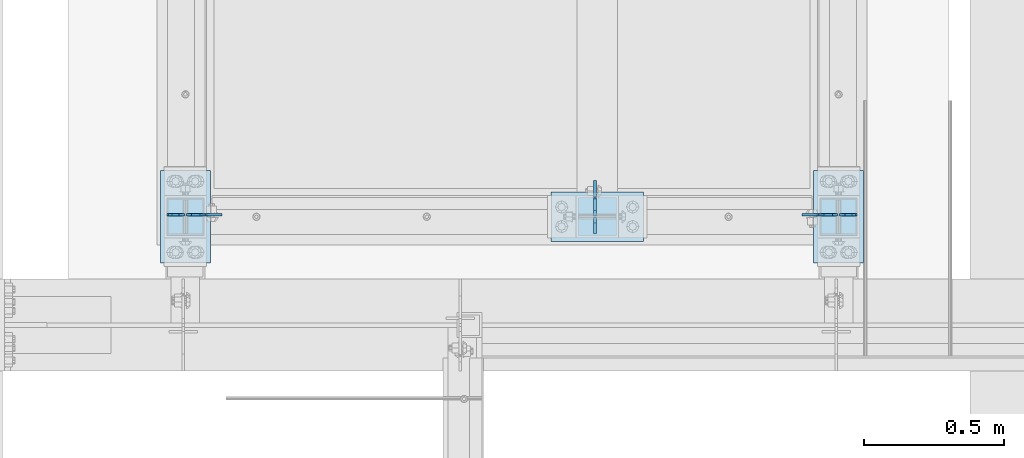
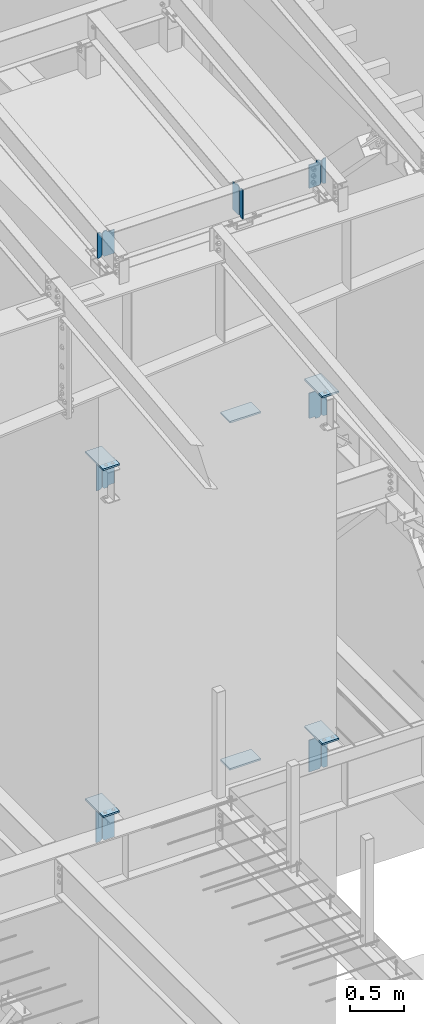
# One storey, part 1008 of 1179: 20 plates, 13 elements without a shape of their own.
"""IFC2X3 building model written with IfcOpenShell, lengths in millimetres."""

from ifc_helpers import new_model, si_unit, frame, origin_with_axes, place, context, subcontext, project, spatial, faceted_brep, material, type_object, element, aggregate, save


model = new_model("IFC2X3")

# Units and contexts
model_context = context("Model", 3, precision=1e-05, world=origin_with_axes())
body_context = subcontext(model_context, "Body", "Model", "MODEL_VIEW")
ifc_project = project(units=[si_unit("LENGTHUNIT", "METRE", prefix="MILLI"), si_unit("AREAUNIT", "SQUARE_METRE"), si_unit("VOLUMEUNIT", "CUBIC_METRE"), si_unit("MASSUNIT", "GRAM", prefix="KILO"), si_unit("TIMEUNIT", "SECOND"), si_unit("PLANEANGLEUNIT", "RADIAN"), si_unit("SOLIDANGLEUNIT", "STERADIAN"), si_unit("THERMODYNAMICTEMPERATUREUNIT", "DEGREE_CELSIUS"), si_unit("LUMINOUSINTENSITYUNIT", "LUMEN")], contexts=[model_context])

# Site, building, storey
site_placement = place(None, origin_with_axes())
site = spatial("IfcSite", under=ifc_project, at=site_placement, CompositionType="ELEMENT")
building_placement = place(site_placement, origin_with_axes())
building = spatial("IfcBuilding", under=site, at=building_placement, Name="Undefined", CompositionType="ELEMENT")
storey_placement = place(building_placement, origin_with_axes())
storey = spatial("IfcBuildingStorey", under=building, at=storey_placement, Name="Undefined", CompositionType="ELEMENT", Elevation=0.0)

# Assembly, plate
assembly_1_placement = place(storey_placement, origin_with_axes())
assembly_1 = element("IfcElementAssembly", 1, at=assembly_1_placement, inside=storey, Name="BEAM", AssemblyPlace="NOTDEFINED", PredefinedType="RIGID_FRAME")
ifc_material = material(Name="STEEL/A36")
plate_type_1 = type_object("IfcPlateType", PredefinedType="NOTDEFINED")
plate_1_placement = place(assembly_1_placement, frame((21479.175, 11876.0879998642, 10289.3409533501), z_axis=(0.0, 0.0, 1.0), x_axis=(1.0, 0.0, 0.0)))
plate_1 = element("IfcPlate", 2, at=plate_1_placement, type_object=plate_type_1, material=ifc_material, Name="PLATE", context=body_context, shape_type="Brep", body=[
    faceted_brep([(0.0, -4.76250000000073, 19.0499992370605), (0.0, -4.76250000000073, 266.862435780953), (0.0, 4.76250000000073, 266.862435780953), (0.0, 4.76250000000073, 19.0499992370605), (19.0499992370605, -4.76250000000073, 285.912435018014), (19.0499992370605, 4.76250000000073, 285.912435018014), (44.4500000000007, -4.76250000000073, 285.912435018014), (44.4500000000007, 4.76250000000073, 285.912435018014), (44.4500000000007, -4.76250000000073, 0.0), (44.4500000000007, 4.76250000000073, 0.0), (19.0499992370605, -4.76250000000073, 0.0), (19.0499992370605, 4.76250000000073, 0.0)], [[[0, 1, 2, 3]], [[1, 4, 5, 2]], [[4, 6, 7, 5]], [[6, 8, 9, 7]], [[8, 10, 11, 9]], [[10, 0, 3, 11]], [[5, 7, 9, 11, 3, 2]], [[10, 8, 6, 4, 1, 0]]]),
])

assembly_2_placement = place(storey_placement, origin_with_axes())
assembly_2 = element("IfcElementAssembly", 3, at=assembly_2_placement, inside=storey, Name="BEAM", AssemblyPlace="NOTDEFINED", PredefinedType="RIGID_FRAME")
plate_2_placement = place(assembly_2_placement, frame((19135.425, 11876.0879998642, 10289.3409533501), z_axis=(0.0, 0.0, 1.0), x_axis=(-1.0, 0.0, 0.0)))
plate_2 = element("IfcPlate", 4, at=plate_2_placement, type_object=plate_type_1, material=ifc_material, Name="PLATE", context=body_context, shape_type="Brep", body=[
    faceted_brep([(0.0, -4.76250000000073, 19.0499992370605), (0.0, -4.76250000000073, 266.862435780953), (0.0, 4.76250000000073, 266.862435780953), (0.0, 4.76250000000073, 19.0499992370605), (19.0499992370605, -4.76250000000073, 285.912435018014), (19.0499992370605, 4.76250000000073, 285.912435018014), (44.4500000000007, -4.76250000000073, 285.912435018014), (44.4500000000007, 4.76250000000073, 285.912435018014), (44.4500000000007, -4.76250000000073, 0.0), (44.4500000000007, 4.76250000000073, 0.0), (19.0499992370605, -4.76250000000073, 0.0), (19.0499992370605, 4.76250000000073, 0.0)], [[[0, 1, 2, 3]], [[1, 4, 5, 2]], [[4, 6, 7, 5]], [[6, 8, 9, 7]], [[8, 10, 11, 9]], [[10, 0, 3, 11]], [[5, 7, 9, 11, 3, 2]], [[10, 8, 6, 4, 1, 0]]]),
])

# Plate
plate_type_2 = type_object("IfcPlateType", PredefinedType="NOTDEFINED")
plate_3_placement = place(assembly_1_placement, frame((21472.225, 11876.0879998611, 10289.3409533498), z_axis=(0.0, 0.0, 1.0), x_axis=(-1.0, 0.0, 0.0)))
plate_3 = element("IfcPlate", 5, at=plate_3_placement, type_object=plate_type_2, material=ifc_material, Name="PLATE", context=body_context, shape_type="Brep", body=[
    faceted_brep([(47.3250000000007, -4.76250000000073, 285.912435018014), (47.3250000000007, -4.76250000000073, 278.748969282953), (47.3250000000007, 4.76250000000073, 278.748969282953), (47.3250000000007, 4.76250000000073, 285.912435018014), (48.2917299225883, -4.76250000000073, 273.888889764907), (48.2917299225883, 4.76250000000073, 273.888889764907), (51.0447438230658, -4.76250000000073, 269.768713296753), (51.0447438230658, 4.76250000000073, 269.768713296753), (55.1649202912195, -4.76250000000073, 267.015699396276), (55.1649202912195, 4.76250000000073, 267.015699396276), (60.0249998092659, -4.76250000000073, 266.048969473688), (60.0249998092659, 4.76250000000073, 266.048969473688), (127.0, -4.76250000000073, 266.048969473688), (127.0, 4.76250000000073, 266.048969473688), (0.0, -4.76250000000073, 266.862435780953), (19.0499992370605, -4.76250000000073, 285.912435018014), (19.0499992370605, 4.76250000000073, 285.912435018014), (0.0, 4.76250000000073, 266.862435780953), (0.0, -4.76250000000073, 19.0499992370605), (0.0, 4.76250000000073, 19.0499992370605), (19.0499992370605, -4.76250000000073, 0.0), (19.0499992370605, 4.76250000000073, 0.0), (127.0, -4.76250000000073, 0.0), (127.0, 4.76250000000073, 0.0)], [[[0, 1, 2, 3]], [[4, 5, 2, 1]], [[6, 7, 5, 4]], [[8, 9, 7, 6]], [[10, 11, 9, 8]], [[12, 13, 11, 10]], [[14, 15, 16, 17]], [[18, 14, 17, 19]], [[20, 18, 19, 21]], [[22, 20, 21, 23]], [[8, 6, 4, 1, 0, 15, 14, 18, 20, 22, 12, 10]], [[16, 15, 0, 3]], [[23, 21, 19, 17, 16, 3, 2, 5, 7, 9, 11, 13]], [[22, 23, 13, 12]]]),
])

aggregate(assembly_1, [plate_1, plate_3])

plate_4_placement = place(assembly_2_placement, frame((19142.375, 11876.0879998611, 10289.3409533498), z_axis=(0.0, 0.0, 1.0), x_axis=(1.0, 0.0, 0.0)))
plate_4 = element("IfcPlate", 6, at=plate_4_placement, type_object=plate_type_2, material=ifc_material, Name="PLATE", context=body_context, shape_type="Brep", body=[
    faceted_brep([(47.3250000000007, -4.76250000000073, 285.912435018014), (47.3250000000007, -4.76250000000073, 278.748969282953), (47.3250000000007, 4.76250000000073, 278.748969282953), (47.3250000000007, 4.76250000000073, 285.912435018014), (48.2917299225883, -4.76250000000073, 273.888889764907), (48.2917299225883, 4.76250000000073, 273.888889764907), (51.0447438230658, -4.76250000000073, 269.768713296753), (51.0447438230658, 4.76250000000073, 269.768713296753), (55.1649202912195, -4.76250000000073, 267.015699396276), (55.1649202912195, 4.76250000000073, 267.015699396276), (60.0249998092659, -4.76250000000073, 266.048969473688), (60.0249998092659, 4.76250000000073, 266.048969473688), (127.0, -4.76250000000073, 266.048969473688), (127.0, 4.76250000000073, 266.048969473688), (0.0, -4.76250000000073, 266.862435780953), (19.0499992370605, -4.76250000000073, 285.912435018014), (19.0499992370605, 4.76250000000073, 285.912435018014), (0.0, 4.76250000000073, 266.862435780953), (0.0, -4.76250000000073, 19.0499992370605), (0.0, 4.76250000000073, 19.0499992370605), (19.0499992370605, -4.76250000000073, 0.0), (19.0499992370605, 4.76250000000073, 0.0), (127.0, -4.76250000000073, 0.0), (127.0, 4.76250000000073, 0.0)], [[[0, 1, 2, 3]], [[4, 5, 2, 1]], [[6, 7, 5, 4]], [[8, 9, 7, 6]], [[10, 11, 9, 8]], [[12, 13, 11, 10]], [[14, 15, 16, 17]], [[18, 14, 17, 19]], [[20, 18, 19, 21]], [[22, 20, 21, 23]], [[8, 6, 4, 1, 0, 15, 14, 18, 20, 22, 12, 10]], [[16, 15, 0, 3]], [[23, 21, 19, 17, 16, 3, 2, 5, 7, 9, 11, 13]], [[22, 23, 13, 12]]]),
])

aggregate(assembly_2, [plate_2, plate_4])

# Assembly, plate
assembly_3_placement = place(storey_placement, origin_with_axes())
assembly_3 = element("IfcElementAssembly", 7, at=assembly_3_placement, inside=storey, Name="BEAM", AssemblyPlace="NOTDEFINED", PredefinedType="RIGID_FRAME")
plate_5_placement = place(assembly_3_placement, frame((20604.1915994836, 11871.3249999452, 10241.0649228246), z_axis=(0.0, 0.0, 1.0), x_axis=(0.0, 1.0, 0.0)))
plate_5 = element("IfcPlate", 8, at=plate_5_placement, type_object=plate_type_2, material=ifc_material, Name="PLATE", context=body_context, shape_type="Brep", body=[
    faceted_brep([(60.3250000095268, -4.76250000000073, 330.200000000001), (60.3250000552471, -4.76250000000073, 326.262915482786), (60.3250000552471, 4.76250000000073, 326.262915482786), (60.3250000095268, 4.76250000000073, 330.200000000001), (61.2917300137196, -4.76250000000073, 321.402836005114), (61.2917300137196, 4.76250000000073, 321.402836005114), (64.0447439211166, -4.76250000000073, 317.282659580787), (64.0447439211166, 4.76250000000073, 317.282659580787), (68.1649203716879, -4.76250000000073, 314.529645712666), (68.1649203716879, 4.76250000000073, 314.529645712666), (73.0249998585768, -4.76250000000073, 313.562915800525), (73.0249998585768, 4.76250000000073, 313.562915800525), (126.999999991474, -4.76250000000073, 313.562915775297), (127.0, 4.76250000000073, 313.562915775297), (0.0, -4.76250000000073, 311.150012969971), (19.0499992370605, -4.76250000000073, 330.200012207031), (19.0499992370605, 4.76250000000073, 330.200012207031), (0.0, 4.76250000000073, 311.150012969971), (0.0, -4.76250000000073, 19.0499992370605), (0.0, 4.76250000000073, 19.0499992370605), (19.0499992370605, -4.76250000000073, 0.0), (19.0499992370605, 4.76250000000073, 0.0), (127.0, -4.76250000000073, 0.0), (127.0, 4.76250000000073, 0.0)], [[[0, 1, 2, 3]], [[4, 5, 2, 1]], [[6, 7, 5, 4]], [[8, 9, 7, 6]], [[10, 11, 9, 8]], [[12, 13, 11, 10]], [[14, 15, 16, 17]], [[18, 14, 17, 19]], [[20, 18, 19, 21]], [[22, 20, 21, 23]], [[8, 6, 4, 1, 0, 15, 14, 18, 20, 22, 12, 10]], [[16, 15, 0, 3]], [[23, 21, 19, 17, 16, 3, 2, 5, 7, 9, 11, 13]], [[22, 23, 13, 12]]]),
])

assembly_4_placement = place(storey_placement, origin_with_axes())
assembly_4 = element("IfcElementAssembly", 9, at=assembly_4_placement, inside=storey, Name="BEAM", AssemblyPlace="NOTDEFINED", PredefinedType="RIGID_FRAME")
plate_6_placement = place(assembly_4_placement, frame((21472.525, 11876.0879999161, 7673.975), z_axis=(0.0, 0.0, 1.0), x_axis=(-1.0, 0.0, 0.0)))
plate_6 = element("IfcPlate", 10, at=plate_6_placement, type_object=plate_type_2, material=ifc_material, Name="PLATE", context=body_context, shape_type="Brep", body=[
    faceted_brep([(60.3246368427681, -4.76250000000073, 0.0), (60.3246379857737, 4.76250000000073, 0.0), (60.3246379857519, 4.76250000000073, 9.52500019075796), (60.3246368427644, -4.76250000000073, 9.52500019075796), (61.2913679083395, 4.76250000000073, 14.385079708798), (61.291366765352, -4.76250000000073, 14.385079708798), (64.0443818088097, 4.76250000000073, 18.5052561769489), (64.0443806658222, -4.76250000000073, 18.5052561769489), (68.1645582769561, 4.76250000000073, 21.2582700774283), (68.1645571339686, -4.76250000000073, 21.2582700774283), (73.0246377949952, 4.76250000000073, 22.2250000000231), (73.0246366520078, -4.76250000000073, 22.2250000000231), (126.999999429587, -4.76250000000073, 22.2250000001213), (127.0, 4.76250000000073, 22.2250000001213), (19.0499992370605, -4.76250000000073, 0.0), (0.0, -4.76250000000073, 19.0499992370605), (0.0, 4.76250000000073, 19.0499992370605), (19.0499992370605, 4.76250000000073, 0.0), (0.0, -4.76250000000073, 311.150012969971), (0.0, 4.76250000000073, 311.150012969971), (19.0499992370605, -4.76250000000073, 330.200012207031), (19.0499992370605, 4.76250000000073, 330.200012207031), (60.3246609394155, -4.76250000000073, 330.2), (60.3246620824211, 4.76250000000073, 330.2), (60.3248055223376, -4.76250000000073, 320.674807040034), (60.324806665325, 4.76250000000073, 320.674807040051), (61.2915907729657, -4.76250000000073, 315.814786720205), (61.2915919159532, 4.76250000000073, 315.814786720222), (64.0446175012585, -4.76250000000073, 311.694675670333), (64.0446186442459, 4.76250000000073, 311.69467567035), (68.1647703397102, -4.76250000000073, 308.941711482811), (68.1647714826977, 4.76250000000073, 308.941711482828), (73.0248053341093, -4.76250000000073, 307.975000004066), (73.0248064770967, 4.76250000000073, 307.975000004083), (126.999999435993, -4.76250000000073, 307.975000020951), (127.0, 4.76250000000073, 307.975000020968)], [[[0, 1, 2, 3]], [[3, 2, 4, 5]], [[5, 4, 6, 7]], [[7, 6, 8, 9]], [[9, 8, 10, 11]], [[12, 11, 10, 13]], [[14, 15, 16, 17]], [[15, 18, 19, 16]], [[18, 20, 21, 19]], [[21, 20, 22, 23]], [[22, 24, 25, 23]], [[26, 27, 25, 24]], [[28, 29, 27, 26]], [[30, 31, 29, 28]], [[32, 33, 31, 30]], [[34, 35, 33, 32]], [[35, 34, 12, 13]], [[8, 6, 4, 2, 1, 17, 16, 19, 21, 23, 25, 27, 29, 31, 33, 35, 13, 10]], [[14, 17, 1, 0]], [[34, 32, 30, 28, 26, 24, 22, 20, 18, 15, 14, 0, 3, 5, 7, 9, 11, 12]]]),
])

assembly_5_placement = place(storey_placement, origin_with_axes())
assembly_5 = element("IfcElementAssembly", 11, at=assembly_5_placement, inside=storey, Name="BEAM", AssemblyPlace="NOTDEFINED", PredefinedType="RIGID_FRAME")
plate_7_placement = place(assembly_5_placement, frame((19142.075, 11876.0879999161, 7673.975), z_axis=(0.0, 0.0, 1.0), x_axis=(1.0, 0.0, 0.0)))
plate_7 = element("IfcPlate", 12, at=plate_7_placement, type_object=plate_type_2, material=ifc_material, Name="PLATE", context=body_context, shape_type="Brep", body=[
    faceted_brep([(60.3249999999971, -4.76250000000073, 0.0), (60.3249999999971, 4.76250000000073, 0.0), (60.3250156291688, 4.76250000000073, 9.52498666129122), (60.3250144861813, -4.76250000000073, 9.52498666129122), (61.2917416701348, 4.76250000000073, 14.3850703337685), (61.2917405271473, -4.76250000000073, 14.3850703337685), (64.0447546716023, 4.76250000000073, 18.5052513923529), (64.0447535286148, -4.76250000000073, 18.5052513923529), (68.1649327990599, 4.76250000000073, 21.2582687805652), (68.1649316560724, -4.76250000000073, 21.2582687805652), (73.0250154422683, 4.76250000000073, 22.2249999960486), (73.0250142992809, -4.76250000000073, 22.2249999960486), (126.999999429587, -4.76250000000073, 22.2250000001213), (127.0, 4.76250000000073, 22.2250000001213), (19.0499992370605, -4.76250000000073, 0.0), (0.0, -4.76250000000073, 19.0499992370605), (0.0, 4.76250000000073, 19.0499992370605), (19.0499992370605, 4.76250000000073, 0.0), (0.0, -4.76250000000073, 311.150012969971), (0.0, 4.76250000000073, 311.150012969971), (19.0499992370605, -4.76250000000073, 330.200012207031), (19.0499992370605, 4.76250000000073, 330.200012207031), (60.3250000095268, -4.76250000000073, 330.200000000001), (60.3250000095268, 4.76250000000073, 330.200000000001), (60.3250000888947, -4.76250000000073, 320.674999707663), (60.3250000888947, 4.76250000000073, 320.674999707663), (61.2917300406407, -4.76250000000073, 315.814920220819), (61.2917300406407, 4.76250000000073, 315.814920220819), (64.0447439478812, -4.76250000000073, 311.694743787144), (64.0447439478812, 4.76250000000073, 311.694743787144), (68.1649204035784, -4.76250000000073, 308.941729912867), (68.1649204035784, 4.76250000000073, 308.941729912867), (73.0249998981599, -4.76250000000073, 307.974999999999), (73.0249998981599, 4.76250000000073, 307.974999999999), (126.999999435993, -4.76250000000073, 307.975000020951), (127.0, 4.76250000000073, 307.975000020968)], [[[0, 1, 2, 3]], [[3, 2, 4, 5]], [[5, 4, 6, 7]], [[7, 6, 8, 9]], [[9, 8, 10, 11]], [[12, 11, 10, 13]], [[14, 15, 16, 17]], [[15, 18, 19, 16]], [[18, 20, 21, 19]], [[21, 20, 22, 23]], [[22, 24, 25, 23]], [[26, 27, 25, 24]], [[28, 29, 27, 26]], [[30, 31, 29, 28]], [[32, 33, 31, 30]], [[34, 35, 33, 32]], [[35, 34, 12, 13]], [[8, 6, 4, 2, 1, 17, 16, 19, 21, 23, 25, 27, 29, 31, 33, 35, 13, 10]], [[0, 14, 17, 1]], [[34, 32, 30, 28, 26, 24, 22, 20, 18, 15, 14, 0, 3, 5, 7, 9, 11, 12]]]),
])

assembly_6_placement = place(storey_placement, origin_with_axes())
assembly_6 = element("IfcElementAssembly", 13, at=assembly_6_placement, inside=storey, Name="BEAM", AssemblyPlace="NOTDEFINED", PredefinedType="RIGID_FRAME")
plate_8_placement = place(assembly_6_placement, frame((21472.525, 11876.0881188012, 3711.575), z_axis=(0.0, 0.0, 1.0), x_axis=(-1.0, 0.0, 0.0)))
plate_8 = element("IfcPlate", 14, at=plate_8_placement, type_object=plate_type_2, material=ifc_material, Name="PLATE", context=body_context, shape_type="Brep", body=[
    faceted_brep([(66.6758007504941, -4.76250000000073, 377.825), (66.6755335395974, -4.76250000000073, 371.475534277462), (66.6755346825848, 4.76250000000073, 371.475534277414), (66.6758018934961, 4.76250000000073, 377.825), (67.6421100582302, -4.76250000000073, 366.615290631913), (67.6421112012176, 4.76250000000073, 366.615290631866), (70.395088391364, -4.76250000000073, 362.494932788501), (70.3950895343514, 4.76250000000073, 362.494932788453), (74.5153303750994, -4.76250000000073, 359.741781057128), (74.5153315180869, 4.76250000000073, 359.74178105708), (79.3755333390509, -4.76250000000073, 358.775000001401), (79.3755344820383, 4.76250000000073, 358.775000001353), (127.000000004868, -4.76249999999709, 358.774999992755), (127.0, 4.76249999999709, 358.774999992755), (0.0, -4.76249999999709, 358.775000762939), (19.0499992370605, -4.76249999999709, 377.825), (19.0499992370605, 4.76249999999709, 377.825), (0.0, 4.76249999999709, 358.775000762939), (0.0, -4.76250000000073, 19.0499992370605), (0.0, 4.76250000000073, 19.0499992370605), (19.0499992370605, -4.76250000000073, 0.0), (19.0499992370605, 4.76250000000073, 0.0), (127.0, -4.76250000000073, 0.0), (127.0, 4.76250000000073, 0.0)], [[[0, 1, 2, 3]], [[4, 5, 2, 1]], [[6, 7, 5, 4]], [[8, 9, 7, 6]], [[10, 11, 9, 8]], [[12, 13, 11, 10]], [[14, 15, 16, 17]], [[18, 14, 17, 19]], [[20, 18, 19, 21]], [[22, 20, 21, 23]], [[8, 6, 4, 1, 0, 15, 14, 18, 20, 22, 12, 10]], [[16, 15, 0, 3]], [[23, 21, 19, 17, 16, 3, 2, 5, 7, 9, 11, 13]], [[22, 23, 13, 12]]]),
])

assembly_7_placement = place(storey_placement, origin_with_axes())
assembly_7 = element("IfcElementAssembly", 15, at=assembly_7_placement, inside=storey, Name="BEAM", AssemblyPlace="NOTDEFINED", PredefinedType="RIGID_FRAME")
plate_9_placement = place(assembly_7_placement, frame((19142.075, 11876.0879999161, 3711.575), z_axis=(0.0, 0.0, 1.0), x_axis=(1.0, 0.0, 0.0)))
plate_9 = element("IfcPlate", 16, at=plate_9_placement, type_object=plate_type_2, material=ifc_material, Name="PLATE", context=body_context, shape_type="Brep", body=[
    faceted_brep([(66.6743865212811, -4.76249999999709, 377.825), (66.6745864763507, -4.76249999999709, 371.474599924168), (66.6745876193563, 4.76249999999709, 371.474599924203), (66.6743876643031, 4.76249999999709, 377.825), (67.6414311678836, -4.76249999999709, 366.614643208318), (67.6414323108893, 4.76249999999709, 366.614643208353), (70.3944716748138, -4.76249999999709, 362.494602443389), (70.3944728178176, 4.76249999999709, 362.494602443423), (74.5145991226364, -4.76249999999709, 359.741691665477), (74.514600265642, 4.76249999999709, 359.741691665511), (79.3745862790947, -4.76249999999709, 358.774999999796), (79.3745874221004, 4.76249999999709, 358.774999999831), (127.000000004868, -4.76249999999709, 358.774999992755), (127.0, 4.76249999999709, 358.774999992755), (0.0, -4.76249999999709, 358.775000762939), (19.0499992370605, -4.76249999999709, 377.825), (19.0499992370605, 4.76249999999709, 377.825), (0.0, 4.76249999999709, 358.775000762939), (0.0, -4.76250000000073, 19.0499992370605), (0.0, 4.76250000000073, 19.0499992370605), (19.0499992370605, -4.76250000000073, 0.0), (19.0499992370605, 4.76250000000073, 0.0), (127.0, -4.76250000000073, 0.0), (127.0, 4.76250000000073, 0.0)], [[[0, 1, 2, 3]], [[4, 5, 2, 1]], [[6, 7, 5, 4]], [[8, 9, 7, 6]], [[10, 11, 9, 8]], [[12, 13, 11, 10]], [[14, 15, 16, 17]], [[18, 14, 17, 19]], [[20, 18, 19, 21]], [[22, 20, 21, 23]], [[8, 6, 4, 1, 0, 15, 14, 18, 20, 22, 12, 10]], [[16, 15, 0, 3]], [[23, 21, 19, 17, 16, 3, 2, 5, 7, 9, 11, 13]], [[22, 23, 13, 12]]]),
])

# Plate
plate_type_3 = type_object("IfcPlateType", PredefinedType="NOTDEFINED")
plate_10_placement = place(assembly_3_placement, frame((20604.1620000841, 11864.9749999452, 10241.0649228246), z_axis=(0.0, 0.0, 1.0), x_axis=(0.0, -1.0, 0.0)))
plate_10 = element("IfcPlate", 17, at=plate_10_placement, type_object=plate_type_3, material=ifc_material, Name="PLATE", context=body_context, shape_type="Brep", body=[
    faceted_brep([(0.0, -4.76250000000073, 19.0499992370605), (0.0, -4.76250000000073, 311.150012969971), (0.0, 4.76250000000073, 311.150012969971), (0.0, 4.76250000000073, 19.0499992370605), (19.0499992370605, -4.76250000000073, 330.200012207031), (19.0499992370605, 4.76250000000073, 330.200012207031), (57.1500015258789, -4.76250000000073, 330.200012207031), (57.1500015258789, 4.76250000000073, 330.200012207031), (57.1500015258789, -4.76250000000073, 0.0), (57.1500015258789, 4.76250000000073, 0.0), (19.0499992370605, -4.76250000000073, 0.0), (19.0499992370605, 4.76250000000073, 0.0)], [[[0, 1, 2, 3]], [[1, 4, 5, 2]], [[4, 6, 7, 5]], [[6, 8, 9, 7]], [[8, 10, 11, 9]], [[10, 0, 3, 11]], [[5, 7, 9, 11, 3, 2]], [[10, 8, 6, 4, 1, 0]]]),
])

aggregate(assembly_3, [plate_10, plate_5])

plate_11_placement = place(assembly_4_placement, frame((21478.875, 11876.0879999161, 7673.975), z_axis=(0.0, 0.0, 1.0), x_axis=(1.0, 0.0, 0.0)))
plate_11 = element("IfcPlate", 18, at=plate_11_placement, type_object=plate_type_3, material=ifc_material, Name="PLATE", context=body_context, shape_type="Brep", body=[
    faceted_brep([(0.0, -4.76250000000073, 19.0499992370605), (0.0, -4.76250000000073, 311.150012969971), (0.0, 4.76250000000073, 311.150012969971), (0.0, 4.76250000000073, 19.0499992370605), (19.0499992370605, -4.76250000000073, 330.200012207031), (19.0499992370605, 4.76250000000073, 330.200012207031), (57.1500015258789, -4.76250000000073, 330.200012207031), (57.1500015258789, 4.76250000000073, 330.200012207031), (57.1500015258789, -4.76250000000073, 0.0), (57.1500015258789, 4.76250000000073, 0.0), (19.0499992370605, -4.76250000000073, 0.0), (19.0499992370605, 4.76250000000073, 0.0)], [[[0, 1, 2, 3]], [[1, 4, 5, 2]], [[4, 6, 7, 5]], [[6, 8, 9, 7]], [[8, 10, 11, 9]], [[10, 0, 3, 11]], [[5, 7, 9, 11, 3, 2]], [[10, 8, 6, 4, 1, 0]]]),
])

aggregate(assembly_4, [plate_11, plate_6])

plate_12_placement = place(assembly_5_placement, frame((19135.725, 11876.0879999161, 7673.975), z_axis=(0.0, 0.0, 1.0), x_axis=(-1.0, 0.0, 0.0)))
plate_12 = element("IfcPlate", 19, at=plate_12_placement, type_object=plate_type_3, material=ifc_material, Name="PLATE", context=body_context, shape_type="Brep", body=[
    faceted_brep([(0.0, -4.76250000000073, 19.0499992370605), (0.0, -4.76250000000073, 311.150012969971), (0.0, 4.76250000000073, 311.150012969971), (0.0, 4.76250000000073, 19.0499992370605), (19.0499992370605, -4.76250000000073, 330.200012207031), (19.0499992370605, 4.76250000000073, 330.200012207031), (57.1500015258789, -4.76250000000073, 330.200012207031), (57.1500015258789, 4.76250000000073, 330.200012207031), (57.1500015258789, -4.76250000000073, 0.0), (57.1500015258789, 4.76250000000073, 0.0), (19.0499992370605, -4.76250000000073, 0.0), (19.0499992370605, 4.76250000000073, 0.0)], [[[0, 1, 2, 3]], [[1, 4, 5, 2]], [[4, 6, 7, 5]], [[6, 8, 9, 7]], [[8, 10, 11, 9]], [[10, 0, 3, 11]], [[5, 7, 9, 11, 3, 2]], [[10, 8, 6, 4, 1, 0]]]),
])

aggregate(assembly_5, [plate_12, plate_7])

# Assembly, plate
assembly_8_placement = place(storey_placement, origin_with_axes())
assembly_8 = element("IfcElementAssembly", 20, at=assembly_8_placement, inside=storey, Name="COLUMN", AssemblyPlace="NOTDEFINED", PredefinedType="RIGID_FRAME")
plate_type_4 = type_object("IfcPlateType", PredefinedType="NOTDEFINED")
plate_13_placement = place(assembly_8_placement, frame((19050.0, 11703.05, 4111.625), z_axis=(0.0, 1.0, 0.0), x_axis=(1.0, 0.0, 0.0)))
plate_13 = element("IfcPlate", 21, at=plate_13_placement, type_object=plate_type_4, material=ifc_material, Name="PLATE", context=body_context, shape_type="Brep", body=[
    faceted_brep([(0.0, -9.52499999999964, 0.0), (0.0, -9.52499999999964, 330.200012207031), (0.0, 9.52499999999964, 330.200012207031), (0.0, 9.52499999999964, 0.0), (177.800003051758, -9.52499999999964, 330.200012207031), (177.800003051758, 9.52499999999964, 330.200012207031), (177.800003051758, -9.52499999999964, 0.0), (177.800003051758, 9.52499999999964, 0.0)], [[[0, 1, 2, 3]], [[1, 4, 5, 2]], [[4, 6, 7, 5]], [[6, 0, 3, 7]], [[5, 7, 3, 2]], [[6, 4, 1, 0]]]),
])
aggregate(assembly_8, [plate_13])

assembly_9_placement = place(storey_placement, origin_with_axes())
assembly_9 = element("IfcElementAssembly", 22, at=assembly_9_placement, inside=storey, Name="COLUMN", AssemblyPlace="NOTDEFINED", PredefinedType="RIGID_FRAME")
plate_14_placement = place(assembly_9_placement, frame((21386.8, 11703.05, 4111.625), z_axis=(0.0, 1.0, 0.0), x_axis=(1.0, 0.0, 0.0)))
plate_14 = element("IfcPlate", 23, at=plate_14_placement, type_object=plate_type_4, material=ifc_material, Name="PLATE", context=body_context, shape_type="Brep", body=[
    faceted_brep([(0.0, -9.52499999999964, 0.0), (0.0, -9.52499999999964, 330.200012207031), (0.0, 9.52499999999964, 330.200012207031), (0.0, 9.52499999999964, 0.0), (177.800003051758, -9.52499999999964, 330.200012207031), (177.800003051758, 9.52499999999964, 330.200012207031), (177.800003051758, -9.52499999999964, 0.0), (177.800003051758, 9.52499999999964, 0.0)], [[[0, 1, 2, 3]], [[1, 4, 5, 2]], [[4, 6, 7, 5]], [[6, 0, 3, 7]], [[5, 7, 3, 2]], [[6, 4, 1, 0]]]),
])
aggregate(assembly_9, [plate_14])

assembly_10_placement = place(storey_placement, origin_with_axes())
assembly_10 = element("IfcElementAssembly", 24, at=assembly_10_placement, inside=storey, Name="COLUMN", AssemblyPlace="NOTDEFINED", PredefinedType="RIGID_FRAME")
plate_15_placement = place(assembly_10_placement, frame((20447.0, 11957.05, 4111.625), z_axis=(1.0, 0.0, 0.0), x_axis=(0.0, -1.0, 0.0)))
plate_15 = element("IfcPlate", 25, at=plate_15_placement, type_object=plate_type_4, material=ifc_material, Name="PLATE", context=body_context, shape_type="Brep", body=[
    faceted_brep([(0.0, -9.52499999999964, 0.0), (0.0, -9.52499999999964, 330.200012207031), (0.0, 9.52499999999964, 330.200012207031), (0.0, 9.52499999999964, 0.0), (177.800003051758, -9.52499999999964, 330.200012207031), (177.800003051758, 9.52499999999964, 330.200012207031), (177.800003051758, -9.52499999999964, 0.0), (177.800003051758, 9.52499999999964, 0.0)], [[[0, 1, 2, 3]], [[1, 4, 5, 2]], [[4, 6, 7, 5]], [[6, 0, 3, 7]], [[5, 7, 3, 2]], [[6, 4, 1, 0]]]),
])
aggregate(assembly_10, [plate_15])

assembly_11_placement = place(storey_placement, origin_with_axes())
assembly_11 = element("IfcElementAssembly", 26, at=assembly_11_placement, inside=storey, Name="COLUMN", AssemblyPlace="NOTDEFINED", PredefinedType="RIGID_FRAME")
plate_16_placement = place(assembly_11_placement, frame((19050.0, 11703.05, 8023.225), z_axis=(0.0, 1.0, 0.0), x_axis=(1.0, 0.0, 0.0)))
plate_16 = element("IfcPlate", 27, at=plate_16_placement, type_object=plate_type_4, material=ifc_material, Name="PLATE", context=body_context, shape_type="Brep", body=[
    faceted_brep([(0.0, -9.52499999999964, 0.0), (0.0, -9.52499999999964, 330.200012207031), (0.0, 9.52499999999964, 330.200012207031), (0.0, 9.52499999999964, 0.0), (177.800003051758, -9.52499999999964, 330.200012207031), (177.800003051758, 9.52499999999964, 330.200012207031), (177.800003051758, -9.52499999999964, 0.0), (177.800003051758, 9.52499999999964, 0.0)], [[[0, 1, 2, 3]], [[1, 4, 5, 2]], [[4, 6, 7, 5]], [[6, 0, 3, 7]], [[5, 7, 3, 2]], [[6, 4, 1, 0]]]),
])
aggregate(assembly_11, [plate_16])

assembly_12_placement = place(storey_placement, origin_with_axes())
assembly_12 = element("IfcElementAssembly", 28, at=assembly_12_placement, inside=storey, Name="COLUMN", AssemblyPlace="NOTDEFINED", PredefinedType="RIGID_FRAME")
plate_17_placement = place(assembly_12_placement, frame((20447.0, 11957.05, 8023.225), z_axis=(1.0, 0.0, 0.0), x_axis=(0.0, -1.0, 0.0)))
plate_17 = element("IfcPlate", 29, at=plate_17_placement, type_object=plate_type_4, material=ifc_material, Name="PLATE", context=body_context, shape_type="Brep", body=[
    faceted_brep([(0.0, -9.52499999999964, 0.0), (0.0, -9.52499999999964, 330.200012207031), (0.0, 9.52499999999964, 330.200012207031), (0.0, 9.52499999999964, 0.0), (177.800003051758, -9.52499999999964, 330.200012207031), (177.800003051758, 9.52499999999964, 330.200012207031), (177.800003051758, -9.52499999999964, 0.0), (177.800003051758, 9.52499999999964, 0.0)], [[[0, 1, 2, 3]], [[1, 4, 5, 2]], [[4, 6, 7, 5]], [[6, 0, 3, 7]], [[5, 7, 3, 2]], [[6, 4, 1, 0]]]),
])
aggregate(assembly_12, [plate_17])

assembly_13_placement = place(storey_placement, origin_with_axes())
assembly_13 = element("IfcElementAssembly", 30, at=assembly_13_placement, inside=storey, Name="COLUMN", AssemblyPlace="NOTDEFINED", PredefinedType="RIGID_FRAME")
plate_18_placement = place(assembly_13_placement, frame((21386.8, 11703.05, 8023.225), z_axis=(0.0, 1.0, 0.0), x_axis=(1.0, 0.0, 0.0)))
plate_18 = element("IfcPlate", 31, at=plate_18_placement, type_object=plate_type_4, material=ifc_material, Name="PLATE", context=body_context, shape_type="Brep", body=[
    faceted_brep([(0.0, -9.52499999999964, 0.0), (0.0, -9.52499999999964, 330.200012207031), (0.0, 9.52499999999964, 330.200012207031), (0.0, 9.52499999999964, 0.0), (177.800003051758, -9.52499999999964, 330.200012207031), (177.800003051758, 9.52499999999964, 330.200012207031), (177.800003051758, -9.52499999999964, 0.0), (177.800003051758, 9.52499999999964, 0.0)], [[[0, 1, 2, 3]], [[1, 4, 5, 2]], [[4, 6, 7, 5]], [[6, 0, 3, 7]], [[5, 7, 3, 2]], [[6, 4, 1, 0]]]),
])
aggregate(assembly_13, [plate_18])

# Plate
plate_type_5 = type_object("IfcPlateType", PredefinedType="NOTDEFINED")
plate_19_placement = place(assembly_7_placement, frame((19135.725, 11876.0879999161, 3711.575), z_axis=(0.0, 0.0, 1.0), x_axis=(-1.0, 0.0, 0.0)))
plate_19 = element("IfcPlate", 32, at=plate_19_placement, type_object=plate_type_5, material=ifc_material, Name="PLATE", context=body_context, shape_type="Brep", body=[
    faceted_brep([(0.0, -4.76250000000073, 19.0499992370605), (0.0, -4.76249999999709, 358.775000762939), (0.0, 4.76249999999709, 358.775000762939), (0.0, 4.76250000000073, 19.0499992370605), (19.0499992370605, -4.76249999999709, 377.825), (19.0499992370605, 4.76249999999709, 377.825), (63.5, -4.76250000000073, 377.825012207031), (63.5, 4.76250000000073, 377.825012207031), (63.5, -4.76250000000073, 0.0), (63.5, 4.76250000000073, 0.0), (19.0499992370605, -4.76250000000073, 0.0), (19.0499992370605, 4.76250000000073, 0.0)], [[[0, 1, 2, 3]], [[1, 4, 5, 2]], [[4, 6, 7, 5]], [[6, 8, 9, 7]], [[8, 10, 11, 9]], [[10, 0, 3, 11]], [[5, 7, 9, 11, 3, 2]], [[10, 8, 6, 4, 1, 0]]]),
])

aggregate(assembly_7, [plate_19, plate_9])

plate_20_placement = place(assembly_6_placement, frame((21478.875, 11876.0881188012, 3711.575), z_axis=(0.0, 0.0, 1.0), x_axis=(1.0, 0.0, 0.0)))
plate_20 = element("IfcPlate", 33, at=plate_20_placement, type_object=plate_type_5, material=ifc_material, Name="PLATE", context=body_context, shape_type="Brep", body=[
    faceted_brep([(0.0, -4.76250000000073, 19.0499992370605), (0.0, -4.76249999999709, 358.775000762939), (0.0, 4.76249999999709, 358.775000762939), (0.0, 4.76250000000073, 19.0499992370605), (19.0499992370605, -4.76249999999709, 377.825), (19.0499992370605, 4.76249999999709, 377.825), (63.5, -4.76250000000073, 377.825012207031), (63.5, 4.76250000000073, 377.825012207031), (63.5, -4.76250000000073, 0.0), (63.5, 4.76250000000073, 0.0), (19.0499992370605, -4.76250000000073, 0.0), (19.0499992370605, 4.76250000000073, 0.0)], [[[0, 1, 2, 3]], [[1, 4, 5, 2]], [[4, 6, 7, 5]], [[6, 8, 9, 7]], [[8, 10, 11, 9]], [[10, 0, 3, 11]], [[5, 7, 9, 11, 3, 2]], [[10, 8, 6, 4, 1, 0]]]),
])

aggregate(assembly_6, [plate_20, plate_8])

save(model, "model.ifc")
